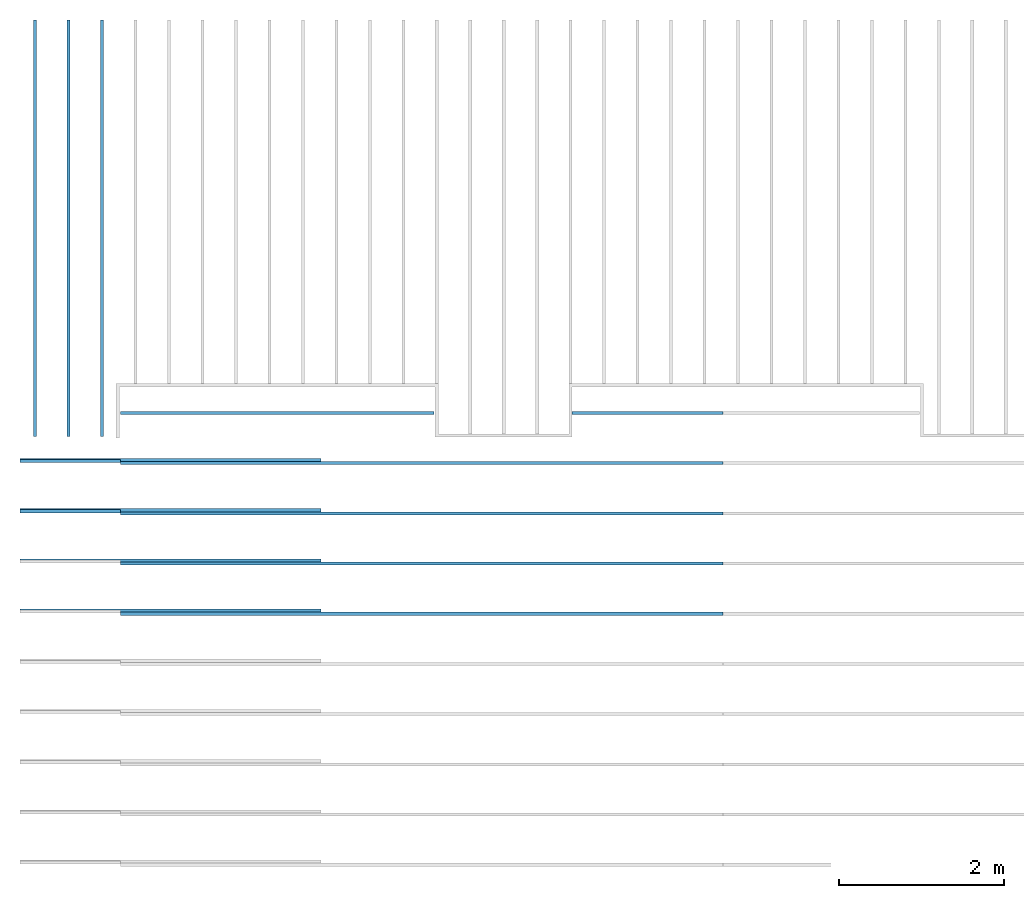
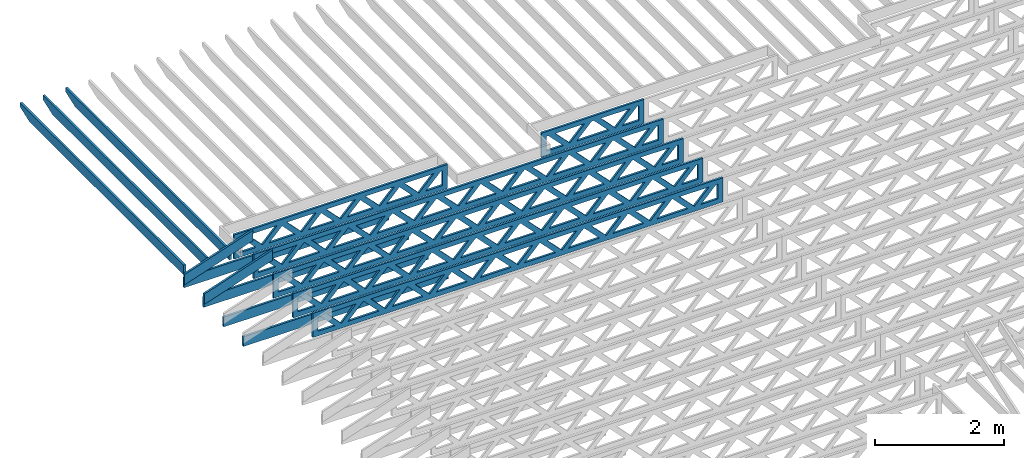
# One storey, part 4 of 18: 15 beams, 4 elements without a shape of their own.
"""IFC4 building model written with IfcOpenShell, lengths in feet."""

from ifc_helpers import new_model, entity, si_unit, converted_unit, derived_unit, direction, frame, frame_2d, origin, origin_2d_with_axis, place, context, subcontext, project, spatial, rectangle, extrude, clip, halfspace, source, transform, mapped, material, material_profile, profile_set, profile_usage, type_object, type_shapes, element, aggregate, save


model = new_model("IFC4")

# Units and contexts
model_context_1 = context("Model", 3, precision=0.0001, world=origin(), true_north=direction((6.12303176911189e-17, 1.0)))
model_context_2 = context("Model", 3, precision=0.0001, world=origin(), true_north=direction((6.12303176911189e-17, 1.0)))
body_context = subcontext(model_context_2, "Body", "Model", "MODEL_VIEW")
ifc_project = project(units=[converted_unit("LENGTHUNIT", "FOOT", entity("IfcRatioMeasure", 0.3048), si_unit("LENGTHUNIT", "METRE"), dimensions=[1, 0, 0, 0, 0, 0, 0]), converted_unit("AREAUNIT", "SQUARE FOOT", entity("IfcRatioMeasure", 0.09290304), si_unit("AREAUNIT", "SQUARE_METRE"), dimensions=[2, 0, 0, 0, 0, 0, 0]), converted_unit("VOLUMEUNIT", "CUBIC FOOT", entity("IfcRatioMeasure", 0.028316846592), si_unit("VOLUMEUNIT", "CUBIC_METRE"), dimensions=[3, 0, 0, 0, 0, 0, 0]), converted_unit("PLANEANGLEUNIT", "DEGREE", entity("IfcRatioMeasure", 0.0174532925199433), si_unit("PLANEANGLEUNIT", "RADIAN"), dimensions=[0, 0, 0, 0, 0, 0, 0]), si_unit("MASSUNIT", "GRAM", prefix="KILO"), derived_unit("MASSDENSITYUNIT", [(si_unit("MASSUNIT", "GRAM", prefix="KILO"), 1), (si_unit("LENGTHUNIT", "METRE"), -3)]), derived_unit("MOMENTOFINERTIAUNIT", [(si_unit("LENGTHUNIT", "METRE"), 4)]), si_unit("TIMEUNIT", "SECOND"), si_unit("FREQUENCYUNIT", "HERTZ"), si_unit("THERMODYNAMICTEMPERATUREUNIT", "DEGREE_CELSIUS"), derived_unit("THERMALTRANSMITTANCEUNIT", [(si_unit("MASSUNIT", "GRAM", prefix="KILO"), 1), (si_unit("THERMODYNAMICTEMPERATUREUNIT", "KELVIN"), -1), (si_unit("TIMEUNIT", "SECOND"), -3)]), derived_unit("VOLUMETRICFLOWRATEUNIT", [(si_unit("LENGTHUNIT", "METRE"), 3), (si_unit("TIMEUNIT", "SECOND"), -1)]), si_unit("ELECTRICCURRENTUNIT", "AMPERE"), si_unit("ELECTRICVOLTAGEUNIT", "VOLT"), si_unit("POWERUNIT", "WATT"), si_unit("FORCEUNIT", "NEWTON"), si_unit("ILLUMINANCEUNIT", "LUX"), si_unit("LUMINOUSFLUXUNIT", "LUMEN"), si_unit("LUMINOUSINTENSITYUNIT", "CANDELA"), derived_unit("USERDEFINED", [(si_unit("MASSUNIT", "GRAM", prefix="KILO"), -1), (si_unit("LENGTHUNIT", "METRE"), -2), (si_unit("TIMEUNIT", "SECOND"), 3), (si_unit("LUMINOUSFLUXUNIT", "LUMEN"), 1)]), derived_unit("LINEARVELOCITYUNIT", [(si_unit("LENGTHUNIT", "METRE"), 1), (si_unit("TIMEUNIT", "SECOND"), -1)]), si_unit("PRESSUREUNIT", "PASCAL"), derived_unit("USERDEFINED", [(si_unit("LENGTHUNIT", "METRE"), -2), (si_unit("MASSUNIT", "GRAM", prefix="KILO"), 1), (si_unit("TIMEUNIT", "SECOND"), -2)]), derived_unit("LINEARFORCEUNIT", [(si_unit("MASSUNIT", "GRAM", prefix="KILO"), 1), (si_unit("LENGTHUNIT", "METRE"), 1), (si_unit("TIMEUNIT", "SECOND"), -2), (si_unit("LENGTHUNIT", "METRE"), -1)]), derived_unit("PLANARFORCEUNIT", [(si_unit("MASSUNIT", "GRAM", prefix="KILO"), 1), (si_unit("LENGTHUNIT", "METRE"), 1), (si_unit("TIMEUNIT", "SECOND"), -2), (si_unit("LENGTHUNIT", "METRE"), -2)])], contexts=[model_context_1])

# Site, building, storey
site_placement = place(None, origin())
site = spatial("IfcSite", under=ifc_project, at=site_placement, CompositionType="ELEMENT")
building_placement = place(site_placement, origin())
building = spatial("IfcBuilding", under=site, at=building_placement, CompositionType="ELEMENT")
storey_placement = place(building_placement, frame((0.0, 0.0, 30.4375000000082)))
storey = spatial("IfcBuildingStorey", under=building, at=storey_placement, Name="ROOF", CompositionType="ELEMENT", Elevation=30.4375000000082)

# Assembly, beams
assembly_1_placement = place(storey_placement, origin())
assembly_1 = element("IfcElementAssembly", 1, at=assembly_1_placement, inside=storey, Name="Structural Beam System:Structural Framing System", ObjectType="Structural Beam System:Structural Framing System", AssemblyPlace="NOTDEFINED", PredefinedType="BEAM_GRID")
ifc_material_1 = material(Name="2X ROOF JOISTS - EXT. STAIN-1 - SEE LIFE SAFETY", Category="Materials")
ifc_material_profile_1 = material_profile(ifc_material_1, rectangle(XDim=0.604166666666667, YDim=0.125000000000011, at=frame_2d((0.0, 0.0), x_axis=(0.0, 1.0))))
ifc_profile_set_1 = profile_set([ifc_material_profile_1])
ifc_profile_usage_1 = profile_usage(ifc_profile_set_1, cardinal=8)
beam_type_1 = type_object("IfcBeamType", PredefinedType="BEAM", material=ifc_profile_set_1)
shared_shape_1 = source(origin(), body_context, "Body", "Clipping", [
    clip(extrude(rectangle(XDim=0.604166666666667, YDim=0.125000000000011, at=frame_2d((0.0, 0.0), x_axis=(0.0, 1.0))), frame((-8.29610169621611, 0.0, 0.0), z_axis=(1.0, 0.0, 0.0), x_axis=(0.0, 1.0, 0.0)), (0.0, 0.0, 1.0), 16.5922033924322), halfspace(frame((-7.32303677682588, -0.0625000000000026, -0.30208333333334), z_axis=(-0.34202014332567, 0.0, -0.939692620785908), x_axis=(0.0, 1.0, 0.0)), False)),
])
type_shapes(beam_type_1, [shared_shape_1])
beam_1_placement = place(assembly_1_placement, frame((-269.133993818795, 965.218429332857, 1.07291666665835), z_axis=(0.0, 0.0, 1.0), x_axis=(0.0, -1.0, 0.0)))
beam_1 = element("IfcBeam", 2, at=beam_1_placement, type_object=beam_type_1, material=ifc_profile_usage_1, PredefinedType="BEAM", context=body_context, shape_type="MappedRepresentation", body=[
    mapped(shared_shape_1, transform((0.0, 0.0, 0.0), scale=1.0)),
])
ifc_profile_usage_2 = profile_usage(ifc_profile_set_1, cardinal=8)
beam_2_placement = place(assembly_1_placement, frame((-267.800660485462, 965.218429332857, 1.07291666665835), z_axis=(0.0, 0.0, 1.0), x_axis=(0.0, -1.0, 0.0)))
beam_2 = element("IfcBeam", 3, at=beam_2_placement, type_object=beam_type_1, material=ifc_profile_usage_2, PredefinedType="BEAM", context=body_context, shape_type="MappedRepresentation", body=[
    mapped(shared_shape_1, transform((0.0, 0.0, 0.0), scale=1.0)),
])
ifc_profile_usage_3 = profile_usage(ifc_profile_set_1, cardinal=8)
beam_3_placement = place(assembly_1_placement, frame((-266.467327152129, 965.218429332857, 1.07291666665835), z_axis=(0.0, 0.0, 1.0), x_axis=(0.0, -1.0, 0.0)))
beam_3 = element("IfcBeam", 4, at=beam_3_placement, type_object=beam_type_1, material=ifc_profile_usage_3, PredefinedType="BEAM", context=body_context, shape_type="MappedRepresentation", body=[
    mapped(shared_shape_1, transform((0.0, 0.0, 0.0), scale=1.0)),
])
aggregate(assembly_1, [beam_1, beam_2, beam_3])

assembly_2_placement = place(storey_placement, origin())
assembly_2 = element("IfcElementAssembly", 5, at=assembly_2_placement, inside=storey, Name="Structural Beam System:Structural Framing System", ObjectType="Structural Beam System:Structural Framing System", AssemblyPlace="NOTDEFINED", PredefinedType="BEAM_GRID")
ifc_material_2 = material(Name="TOP CHORD OF FIELD FRAMED OVERHANG", Category="Materials")
ifc_material_profile_2 = material_profile(ifc_material_2, rectangle(XDim=0.604166666666667, YDim=0.125, at=origin_2d_with_axis()), Name="2X8 TOP CHORD")
ifc_profile_set_2 = profile_set([ifc_material_profile_2], Name="2X8 TOP CHORD")
ifc_profile_usage_4 = profile_usage(ifc_profile_set_2, cardinal=8)
beam_type_2 = type_object("IfcBeamType", Name="Dimension Lumber - Ends:2X8 TOP CHORD", PredefinedType="BEAM", material=ifc_profile_set_2)
shared_shape_2 = source(origin(), body_context, "Body", "Clipping", [
    clip(clip(extrude(rectangle(XDim=0.604166666666671, YDim=0.125, at=frame_2d((-1.83186799063151e-15, 0.0), x_axis=(1.0, 0.0))), frame((-2.10819527564865, 0.0, 0.0), z_axis=(1.0, 0.0, 0.0), x_axis=(0.0, 0.0, -1.0)), (0.0, 0.0, 1.0), 4.41772145980974), halfspace(frame((2.10819527564862, -0.0625000000000025, -0.302083333333339), z_axis=(0.948710608132914, 0.0, -0.316145823973807), x_axis=(0.0, 1.0, 0.0)), False)), halfspace(frame((-1.90686436713617, -0.0625000000000025, 0.302083333333328), z_axis=(-0.948710608132914, 0.0, 0.316145823973807), x_axis=(0.0, 1.0, 0.0)), False)),
])
type_shapes(beam_type_2, [shared_shape_2])
beam_4_placement = place(assembly_2_placement, frame((-267.833654839365, 953.945265019167, 1.93690371042362), z_axis=(-0.316227766016838, 0.0, 0.948683298050514), x_axis=(0.948683298050514, 0.0, 0.316227766016837)))
beam_4 = element("IfcBeam", 6, at=beam_4_placement, type_object=beam_type_2, material=ifc_profile_usage_4, Name="Dimension Lumber - Ends:2X8 TOP CHORD", ObjectType="Dimension Lumber - Ends:2X8 TOP CHORD", PredefinedType="BEAM", context=body_context, shape_type="MappedRepresentation", body=[
    mapped(shared_shape_2, transform((0.0, 0.0, 0.0), scale=1.0)),
])
ifc_profile_usage_5 = profile_usage(ifc_profile_set_2, cardinal=8)
beam_5_placement = place(assembly_2_placement, frame((-267.833654839365, 955.945265019167, 1.93690371042362), z_axis=(-0.316227766016838, 0.0, 0.948683298050514), x_axis=(0.948683298050514, 0.0, 0.316227766016837)))
beam_5 = element("IfcBeam", 7, at=beam_5_placement, type_object=beam_type_2, material=ifc_profile_usage_5, Name="Dimension Lumber - Ends:2X8 TOP CHORD", ObjectType="Dimension Lumber - Ends:2X8 TOP CHORD", PredefinedType="BEAM", context=body_context, shape_type="MappedRepresentation", body=[
    mapped(shared_shape_2, transform((0.0, 0.0, 0.0), scale=1.0)),
])
aggregate(assembly_2, [beam_4, beam_5])

assembly_3_placement = place(storey_placement, origin())
assembly_3 = element("IfcElementAssembly", 8, at=assembly_3_placement, inside=storey, Name="Structural Beam System:Structural Framing System", ObjectType="Structural Beam System:Structural Framing System", AssemblyPlace="NOTDEFINED", PredefinedType="BEAM_GRID")
ifc_material_3 = material(Name="2X8 TO ROOF", Category="Materials")
ifc_material_profile_3 = material_profile(ifc_material_3, rectangle(XDim=0.604166666666667, YDim=0.125000000000011, at=origin_2d_with_axis()), Name="2X8")
ifc_profile_set_3 = profile_set([ifc_material_profile_3], Name="2X8")
ifc_profile_usage_6 = profile_usage(ifc_profile_set_3, cardinal=8)
beam_type_3 = type_object("IfcBeamType", Name="061100 - Wood Framing:2X8", PredefinedType="BEAM", material=ifc_profile_set_3)
shared_shape_3 = source(origin(), body_context, "Body", "SweptSolid", [
    extrude(rectangle(XDim=0.604166666666667, YDim=0.125000000000011, at=origin_2d_with_axis()), frame((-6.0, 0.0, 0.0), z_axis=(1.0, 0.0, 0.0), x_axis=(0.0, 0.0, -1.0)), (0.0, 0.0, 1.0), 12.000000000033),
])
type_shapes(beam_type_3, [shared_shape_3])
beam_6_placement = place(assembly_3_placement, frame((-263.738072841597, 951.986939927996, 1.07291666665841), z_axis=(0.0, 0.0, 1.0), x_axis=(-1.0, 0.0, 0.0)))
beam_6 = element("IfcBeam", 9, at=beam_6_placement, type_object=beam_type_3, material=ifc_profile_usage_6, Name="061100 - Wood Framing:2X8", ObjectType="061100 - Wood Framing:2X8", PredefinedType="BEAM", context=body_context, shape_type="MappedRepresentation", body=[
    mapped(shared_shape_3, transform((0.0, 0.0, 0.0), scale=1.0)),
])
ifc_profile_usage_7 = profile_usage(ifc_profile_set_3, cardinal=8)
beam_7_placement = place(assembly_3_placement, frame((-263.738087916709, 949.986939927882, 1.07291666665841), z_axis=(0.0, 0.0, 1.0), x_axis=(-1.0, 0.0, 0.0)))
beam_7 = element("IfcBeam", 10, at=beam_7_placement, type_object=beam_type_3, material=ifc_profile_usage_7, Name="061100 - Wood Framing:2X8", ObjectType="061100 - Wood Framing:2X8", PredefinedType="BEAM", context=body_context, shape_type="MappedRepresentation", body=[
    mapped(shared_shape_3, transform((0.0, 0.0, 0.0), scale=1.0)),
])
ifc_profile_usage_8 = profile_usage(ifc_profile_set_3, cardinal=8)
beam_8_placement = place(assembly_3_placement, frame((-263.738042691372, 955.986939928224, 1.0729166666584), z_axis=(0.0, 0.0, 1.0), x_axis=(-1.0, 0.0, 0.0)))
beam_8 = element("IfcBeam", 11, at=beam_8_placement, type_object=beam_type_3, material=ifc_profile_usage_8, Name="061100 - Wood Framing:2X8", ObjectType="061100 - Wood Framing:2X8", PredefinedType="BEAM", context=body_context, shape_type="MappedRepresentation", body=[
    mapped(shared_shape_3, transform((0.0, 0.0, 0.0), scale=1.0)),
])
ifc_profile_usage_9 = profile_usage(ifc_profile_set_3, cardinal=8)
beam_9_placement = place(assembly_3_placement, frame((-263.738057766485, 953.98693992811, 1.0729166666584), z_axis=(0.0, 0.0, 1.0), x_axis=(-1.0, 0.0, 0.0)))
beam_9 = element("IfcBeam", 12, at=beam_9_placement, type_object=beam_type_3, material=ifc_profile_usage_9, Name="061100 - Wood Framing:2X8", ObjectType="061100 - Wood Framing:2X8", PredefinedType="BEAM", context=body_context, shape_type="MappedRepresentation", body=[
    mapped(shared_shape_3, transform((0.0, 0.0, 0.0), scale=1.0)),
])
aggregate(assembly_3, [beam_6, beam_7, beam_8, beam_9])

assembly_4_placement = place(storey_placement, origin())
assembly_4 = element("IfcElementAssembly", 13, at=assembly_4_placement, inside=storey, Name="Structural Beam System:Structural Framing System", ObjectType="Structural Beam System:Structural Framing System", AssemblyPlace="NOTDEFINED", PredefinedType="BEAM_GRID")
ifc_material_4 = material(Name="WOOD TRUSS", Category="Materials")
ifc_material_profile_4 = material_profile(ifc_material_4, rectangle(XDim=1.73473973950632, YDim=0.125, at=origin_2d_with_axis()))
ifc_material_profile_5 = material_profile(ifc_material_4, rectangle(XDim=1.73473973950633, YDim=0.125, at=frame_2d((-1.11022302462516e-16, 0.0), x_axis=(1.0, 0.0))))
ifc_material_profile_6 = material_profile(ifc_material_4, rectangle(XDim=1.73473973950632, YDim=0.125, at=origin_2d_with_axis()))
ifc_material_profile_7 = material_profile(ifc_material_4, rectangle(XDim=1.73473973950633, YDim=0.125, at=origin_2d_with_axis()))
ifc_material_profile_8 = material_profile(ifc_material_4, rectangle(XDim=1.73473973950632, YDim=0.125, at=frame_2d((-5.55111512312578e-17, 0.0), x_axis=(1.0, 0.0))))
ifc_material_profile_9 = material_profile(ifc_material_4, rectangle(XDim=1.73473973950633, YDim=0.125, at=frame_2d((-2.77555756156289e-16, 0.0), x_axis=(1.0, 0.0))))
ifc_material_profile_10 = material_profile(ifc_material_4, rectangle(XDim=1.73473973950632, YDim=0.125, at=frame_2d((-4.9960036108132e-16, 0.0), x_axis=(1.0, 0.0))))
ifc_material_profile_11 = material_profile(ifc_material_4, rectangle(XDim=1.73473973950633, YDim=0.125, at=frame_2d((4.44089209850063e-16, 0.0), x_axis=(1.0, 0.0))))
ifc_material_profile_12 = material_profile(ifc_material_4, rectangle(XDim=1.73473973950632, YDim=0.125, at=origin_2d_with_axis()))
ifc_material_profile_13 = material_profile(ifc_material_4, rectangle(XDim=1.73473973950633, YDim=0.125, at=frame_2d((-4.9960036108132e-16, 0.0), x_axis=(1.0, 0.0))))
ifc_material_profile_14 = material_profile(ifc_material_4, rectangle(XDim=0.291666666666664, YDim=0.125, at=frame_2d((-2.77555756156289e-17, 0.0), x_axis=(1.0, 0.0))))
ifc_material_profile_15 = material_profile(ifc_material_4, rectangle(XDim=0.291666666666628, YDim=0.124999999999995, at=frame_2d((-5.55111512312578e-17, 0.0), x_axis=(1.0, 0.0))))
ifc_material_profile_16 = material_profile(ifc_material_4, rectangle(XDim=0.916666666666666, YDim=0.125000000000003, at=frame_2d((-2.77555756156289e-17, 0.0), x_axis=(1.0, 0.0))))
ifc_material_profile_17 = material_profile(ifc_material_4, rectangle(XDim=0.916666666666651, YDim=0.125, at=frame_2d((-2.77555756156289e-17, 0.0), x_axis=(1.0, 0.0))))
ifc_profile_set_4 = profile_set([ifc_material_profile_4, ifc_material_profile_5, ifc_material_profile_6, ifc_material_profile_7, ifc_material_profile_8, ifc_material_profile_9, ifc_material_profile_10, ifc_material_profile_11, ifc_material_profile_12, ifc_material_profile_13, ifc_material_profile_14, ifc_material_profile_15, ifc_material_profile_16, ifc_material_profile_17])
ifc_profile_usage_10 = profile_usage(ifc_profile_set_4, cardinal=8)
beam_type_4 = type_object("IfcBeamType", PredefinedType="BEAM", material=ifc_profile_set_4)
shared_shape_4 = source(origin(), body_context, "Body", "SweptSolid", [
    extrude(rectangle(XDim=1.73473973950632, YDim=0.125, at=frame_2d((8.88178419700125e-16, 0.0), x_axis=(1.0, 0.0))), frame((8.27006284966195, 0.0, 0.101118361020562), z_axis=(0.720569184836762, 0.0, -0.693383046997606), x_axis=(0.693383046997606, 0.0, 0.720569184836762)), (0.0, 0.0, 1.0), 0.291666666666667),
    extrude(rectangle(XDim=1.73473973950633, YDim=0.125, at=frame_2d((4.9960036108132e-16, 0.0), x_axis=(1.0, 0.0))), frame((7.01977697598868, 0.0, -0.101118361020407), z_axis=(0.720569184836758, 0.0, 0.69338304699761), x_axis=(0.69338304699761, 0.0, -0.720569184836758)), (0.0, 0.0, 1.0), 0.291666666666667),
    extrude(rectangle(XDim=1.73473973950632, YDim=0.125, at=origin_2d_with_axis()), frame((5.68672854334628, 0.0, 0.101118361020562), z_axis=(0.720569184836762, 0.0, -0.693383046997606), x_axis=(0.693383046997606, 0.0, 0.720569184836762)), (0.0, 0.0, 1.0), 0.291666666666667),
    extrude(rectangle(XDim=1.73473973950633, YDim=0.125, at=frame_2d((-4.9960036108132e-16, 0.0), x_axis=(1.0, 0.0))), frame((4.43644266967301, 0.0, -0.101118361020407), z_axis=(0.720569184836758, 0.0, 0.69338304699761), x_axis=(0.69338304699761, 0.0, -0.720569184836758)), (0.0, 0.0, 1.0), 0.291666666666667),
    extrude(rectangle(XDim=1.73473973950632, YDim=0.125, at=frame_2d((3.33066907387547e-16, 0.0), x_axis=(1.0, 0.0))), frame((3.10339423703061, 0.0, 0.101118361020562), z_axis=(0.720569184836762, 0.0, -0.693383046997606), x_axis=(0.693383046997606, 0.0, 0.720569184836762)), (0.0, 0.0, 1.0), 0.291666666666667),
    extrude(rectangle(XDim=1.73473973950633, YDim=0.125, at=frame_2d((-1.11022302462516e-16, 0.0), x_axis=(1.0, 0.0))), frame((1.85310836335734, 0.0, -0.101118361020407), z_axis=(0.720569184836758, 0.0, 0.69338304699761), x_axis=(0.69338304699761, 0.0, -0.720569184836758)), (0.0, 0.0, 1.0), 0.291666666666666),
    extrude(rectangle(XDim=1.73473973950632, YDim=0.125, at=frame_2d((5.55111512312578e-17, 0.0), x_axis=(1.0, 0.0))), frame((0.520059930714937, 0.0, 0.101118361020562), z_axis=(0.720569184836762, 0.0, -0.693383046997606), x_axis=(0.693383046997606, 0.0, 0.720569184836762)), (0.0, 0.0, 1.0), 0.291666666666667),
    extrude(rectangle(XDim=1.73473973950633, YDim=0.125, at=origin_2d_with_axis()), frame((-0.730225942958334, 0.0, -0.101118361020407), z_axis=(0.720569184836758, 0.0, 0.69338304699761), x_axis=(0.69338304699761, 0.0, -0.720569184836758)), (0.0, 0.0, 1.0), 0.291666666666666),
    extrude(rectangle(XDim=1.73473973950632, YDim=0.125, at=frame_2d((-5.55111512312578e-17, 0.0), x_axis=(1.0, 0.0))), frame((-2.06327437560074, 0.0, 0.101118361020562), z_axis=(0.720569184836762, 0.0, -0.693383046997606), x_axis=(0.693383046997606, 0.0, 0.720569184836762)), (0.0, 0.0, 1.0), 0.291666666666667),
    extrude(rectangle(XDim=1.73473973950633, YDim=0.125, at=frame_2d((-2.77555756156289e-16, 0.0), x_axis=(1.0, 0.0))), frame((-3.31356024927401, 0.0, -0.101118361020407), z_axis=(0.720569184836758, 0.0, 0.69338304699761), x_axis=(0.69338304699761, 0.0, -0.720569184836758)), (0.0, 0.0, 1.0), 0.291666666666666),
    extrude(rectangle(XDim=1.73473973950632, YDim=0.125, at=origin_2d_with_axis()), frame((-4.64660868191641, 0.0, 0.101118361020562), z_axis=(0.720569184836762, 0.0, -0.693383046997606), x_axis=(0.693383046997606, 0.0, 0.720569184836762)), (0.0, 0.0, 1.0), 0.291666666666667),
    extrude(rectangle(XDim=1.73473973950633, YDim=0.125, at=frame_2d((-4.9960036108132e-16, 0.0), x_axis=(1.0, 0.0))), frame((-5.89689455558968, 0.0, -0.101118361020407), z_axis=(0.720569184836758, 0.0, 0.69338304699761), x_axis=(0.69338304699761, 0.0, -0.720569184836758)), (0.0, 0.0, 1.0), 0.291666666666667),
    extrude(rectangle(XDim=1.73473973950632, YDim=0.125, at=frame_2d((5.55111512312578e-16, 0.0), x_axis=(1.0, 0.0))), frame((-7.22994298823208, 0.0, 0.101118361020562), z_axis=(0.720569184836762, 0.0, -0.693383046997606), x_axis=(0.693383046997606, 0.0, 0.720569184836762)), (0.0, 0.0, 1.0), 0.291666666666667),
    extrude(rectangle(XDim=1.73473973950633, YDim=0.125, at=origin_2d_with_axis()), frame((-8.48022886190535, 0.0, -0.101118361020407), z_axis=(0.720569184836758, 0.0, 0.69338304699761), x_axis=(0.69338304699761, 0.0, -0.720569184836758)), (0.0, 0.0, 1.0), 0.291666666666666),
    extrude(rectangle(XDim=1.73473973950632, YDim=0.125, at=frame_2d((-8.88178419700125e-16, 0.0), x_axis=(1.0, 0.0))), frame((10.8533971559776, 0.0, 0.101118361020503), z_axis=(0.720569184836762, 0.0, -0.693383046997606), x_axis=(0.693383046997606, 0.0, 0.720569184836762)), (0.0, 0.0, 1.0), 0.291666666666664),
    extrude(rectangle(XDim=1.73473973950633, YDim=0.125, at=origin_2d_with_axis()), frame((9.60311128230435, 0.0, -0.101118361020466), z_axis=(0.720569184836758, 0.0, 0.69338304699761), x_axis=(0.69338304699761, 0.0, -0.720569184836758)), (0.0, 0.0, 1.0), 0.291666666666666),
    extrude(rectangle(XDim=1.73473973950632, YDim=0.125, at=frame_2d((8.88178419700125e-16, 0.0), x_axis=(1.0, 0.0))), frame((-9.81327729454775, 0.0, 0.101118361020564), z_axis=(0.720569184836762, 0.0, -0.693383046997606), x_axis=(0.693383046997606, 0.0, 0.720569184836762)), (0.0, 0.0, 1.0), 0.291666666666667),
    extrude(rectangle(XDim=1.73473973950633, YDim=0.125, at=origin_2d_with_axis()), frame((-11.063563168221, 0.0, -0.101118361020405), z_axis=(0.720569184836758, 0.0, 0.69338304699761), x_axis=(0.69338304699761, 0.0, -0.720569184836758)), (0.0, 0.0, 1.0), 0.291666666666666),
    extrude(rectangle(XDim=0.291666666666664, YDim=0.125, at=frame_2d((-2.77555756156289e-17, 0.0), x_axis=(1.0, 0.0))), frame((-12.0000038919293, 0.0, 0.604166666666611), z_axis=(1.0, 0.0, 0.0), x_axis=(0.0, 0.0, -1.0)), (0.0, 0.0, 1.0), 24.0000077838585),
    extrude(rectangle(XDim=0.291666666666628, YDim=0.124999999999995, at=frame_2d((-5.55111512312578e-17, 0.0), x_axis=(1.0, 0.0))), frame((-12.0000038919291, 0.0, -0.604166666666693), z_axis=(1.0, 0.0, 0.0), x_axis=(0.0, 0.0, -1.0)), (0.0, 0.0, 1.0), 24.0000077838583),
    extrude(rectangle(XDim=0.916666666666666, YDim=0.125000000000003, at=frame_2d((-2.77555756156289e-17, 0.0), x_axis=(1.0, 0.0))), frame((11.7083372252626, 0.0, 0.0), z_axis=(1.0, 0.0, 0.0), x_axis=(0.0, 0.0, -1.0)), (0.0, 0.0, 1.0), 0.291666666666687),
    extrude(rectangle(XDim=0.916666666666651, YDim=0.125, at=frame_2d((-2.77555756156289e-17, 0.0), x_axis=(1.0, 0.0))), frame((-12.0000038919293, 0.0, 0.0), z_axis=(1.0, 0.0, 0.0), x_axis=(0.0, 0.0, -1.0)), (0.0, 0.0, 1.0), 0.291666666666687),
])
type_shapes(beam_type_4, [shared_shape_4])
beam_10_placement = place(assembly_4_placement, frame((-253.738164377457, 949.861934882651, 0.749999999991633)))
beam_10 = element("IfcBeam", 14, at=beam_10_placement, type_object=beam_type_4, material=ifc_profile_usage_10, PredefinedType="BEAM", context=body_context, shape_type="MappedRepresentation", body=[
    mapped(shared_shape_4, transform((0.0, 0.0, 0.0), scale=1.0)),
])
ifc_profile_usage_11 = profile_usage(ifc_profile_set_4, cardinal=8)
beam_11_placement = place(assembly_4_placement, frame((-253.738164377457, 955.861934882651, 0.749999999991619)))
beam_11 = element("IfcBeam", 15, at=beam_11_placement, type_object=beam_type_4, material=ifc_profile_usage_11, PredefinedType="BEAM", context=body_context, shape_type="MappedRepresentation", body=[
    mapped(shared_shape_4, transform((0.0, 0.0, 0.0), scale=1.0)),
])
ifc_profile_usage_12 = profile_usage(ifc_profile_set_4, cardinal=8)
beam_12_placement = place(assembly_4_placement, frame((-253.738164377457, 951.861934882651, 0.74999999999163)))
beam_12 = element("IfcBeam", 16, at=beam_12_placement, type_object=beam_type_4, material=ifc_profile_usage_12, PredefinedType="BEAM", context=body_context, shape_type="MappedRepresentation", body=[
    mapped(shared_shape_4, transform((0.0, 0.0, 0.0), scale=1.0)),
])
ifc_profile_usage_13 = profile_usage(ifc_profile_set_4, cardinal=8)
beam_13_placement = place(assembly_4_placement, frame((-253.738164377457, 953.861934882651, 0.749999999991623)))
beam_13 = element("IfcBeam", 17, at=beam_13_placement, type_object=beam_type_4, material=ifc_profile_usage_13, PredefinedType="BEAM", context=body_context, shape_type="MappedRepresentation", body=[
    mapped(shared_shape_4, transform((0.0, 0.0, 0.0), scale=1.0)),
])
ifc_profile_usage_14 = profile_usage(ifc_profile_set_4, cardinal=8)
beam_type_5 = type_object("IfcBeamType", PredefinedType="BEAM", material=ifc_profile_set_4)
shared_shape_5 = source(origin(), body_context, "Body", "SweptSolid", [
    extrude(rectangle(XDim=1.73473973950632, YDim=0.125, at=origin_2d_with_axis()), frame((2.81172855039779, 0.0, 0.101118361020562), z_axis=(0.720569184836762, 0.0, -0.693383046997606), x_axis=(0.693383046997606, 0.0, 0.720569184836762)), (0.0, 0.0, 1.0), 0.291666666666667),
    extrude(rectangle(XDim=1.73473973950633, YDim=0.125, at=frame_2d((-1.11022302462516e-16, 0.0), x_axis=(1.0, 0.0))), frame((1.56144267672452, 0.0, -0.101118361020407), z_axis=(0.720569184836758, 0.0, 0.69338304699761), x_axis=(0.69338304699761, 0.0, -0.720569184836758)), (0.0, 0.0, 1.0), 0.291666666666666),
    extrude(rectangle(XDim=1.73473973950632, YDim=0.125, at=origin_2d_with_axis()), frame((0.520059930714936, 0.0, 0.101118361020562), z_axis=(0.720569184836762, 0.0, -0.693383046997606), x_axis=(0.693383046997606, 0.0, 0.720569184836762)), (0.0, 0.0, 1.0), 0.291666666666667),
    extrude(rectangle(XDim=1.73473973950633, YDim=0.125, at=origin_2d_with_axis()), frame((-0.730225942958334, 0.0, -0.101118361020407), z_axis=(0.720569184836758, 0.0, 0.69338304699761), x_axis=(0.69338304699761, 0.0, -0.720569184836758)), (0.0, 0.0, 1.0), 0.291666666666666),
    extrude(rectangle(XDim=1.73473973950632, YDim=0.125, at=frame_2d((-5.55111512312578e-17, 0.0), x_axis=(1.0, 0.0))), frame((-1.77160868896792, 0.0, 0.101118361020562), z_axis=(0.720569184836762, 0.0, -0.693383046997606), x_axis=(0.693383046997606, 0.0, 0.720569184836762)), (0.0, 0.0, 1.0), 0.291666666666667),
    extrude(rectangle(XDim=1.73473973950633, YDim=0.125, at=frame_2d((-2.77555756156289e-16, 0.0), x_axis=(1.0, 0.0))), frame((-3.02189456264119, 0.0, -0.101118361020407), z_axis=(0.720569184836758, 0.0, 0.69338304699761), x_axis=(0.69338304699761, 0.0, -0.720569184836758)), (0.0, 0.0, 1.0), 0.291666666666666),
    extrude(rectangle(XDim=1.73473973950632, YDim=0.125, at=frame_2d((-4.9960036108132e-16, 0.0), x_axis=(1.0, 0.0))), frame((5.10339717008065, 0.0, 0.101118361020511), z_axis=(0.720569184836761, 0.0, -0.693383046997607), x_axis=(0.693383046997607, 0.0, 0.720569184836761)), (0.0, 0.0, 1.0), 0.291666666666668),
    extrude(rectangle(XDim=1.73473973950633, YDim=0.125, at=frame_2d((4.44089209850063e-16, 0.0), x_axis=(1.0, 0.0))), frame((3.85311129640737, 0.0, -0.101118361020458), z_axis=(0.720569184836758, 0.0, 0.69338304699761), x_axis=(0.69338304699761, 0.0, -0.720569184836758)), (0.0, 0.0, 1.0), 0.291666666666666),
    extrude(rectangle(XDim=1.73473973950632, YDim=0.125, at=origin_2d_with_axis()), frame((-4.06327730865077, 0.0, 0.101118361020557), z_axis=(0.720569184836762, 0.0, -0.693383046997606), x_axis=(0.693383046997606, 0.0, 0.720569184836762)), (0.0, 0.0, 1.0), 0.291666666666668),
    extrude(rectangle(XDim=1.73473973950633, YDim=0.125, at=frame_2d((-4.9960036108132e-16, 0.0), x_axis=(1.0, 0.0))), frame((-5.31356318232404, 0.0, -0.101118361020412), z_axis=(0.720569184836758, 0.0, 0.69338304699761), x_axis=(0.69338304699761, 0.0, -0.720569184836758)), (0.0, 0.0, 1.0), 0.291666666666667),
    extrude(rectangle(XDim=0.291666666666664, YDim=0.125, at=frame_2d((-2.77555756156289e-17, 0.0), x_axis=(1.0, 0.0))), frame((-6.25000390603229, 0.0, 0.604166666666611), z_axis=(1.0, 0.0, 0.0), x_axis=(0.0, 0.0, -1.0)), (0.0, 0.0, 1.0), 12.5000078120646),
    extrude(rectangle(XDim=0.291666666666628, YDim=0.124999999999995, at=frame_2d((-5.55111512312578e-17, 0.0), x_axis=(1.0, 0.0))), frame((-6.25000390603208, 0.0, -0.604166666666693), z_axis=(1.0, 0.0, 0.0), x_axis=(0.0, 0.0, -1.0)), (0.0, 0.0, 1.0), 12.5000078120644),
    extrude(rectangle(XDim=0.916666666666666, YDim=0.125000000000003, at=frame_2d((-2.77555756156289e-17, 0.0), x_axis=(1.0, 0.0))), frame((5.9583372393656, 0.0, 0.0), z_axis=(1.0, 0.0, 0.0), x_axis=(0.0, 0.0, -1.0)), (0.0, 0.0, 1.0), 0.291666666666687),
    extrude(rectangle(XDim=0.916666666666651, YDim=0.125, at=frame_2d((-2.77555756156289e-17, 0.0), x_axis=(1.0, 0.0))), frame((-6.25000390603229, 0.0, 0.0), z_axis=(1.0, 0.0, 0.0), x_axis=(0.0, 0.0, -1.0)), (0.0, 0.0, 1.0), 0.291666666666687),
])
type_shapes(beam_type_5, [shared_shape_5])
beam_14_placement = place(assembly_4_placement, frame((-259.488164363354, 957.861934882651, 0.749999999991619)))
beam_14 = element("IfcBeam", 18, at=beam_14_placement, type_object=beam_type_5, material=ifc_profile_usage_14, PredefinedType="BEAM", context=body_context, shape_type="MappedRepresentation", body=[
    mapped(shared_shape_5, transform((0.0, 0.0, 0.0), scale=1.0)),
])
ifc_profile_usage_15 = profile_usage(ifc_profile_set_4, cardinal=8)
beam_type_6 = type_object("IfcBeamType", PredefinedType="BEAM", material=ifc_profile_set_4)
shared_shape_6 = source(origin(), body_context, "Body", "SweptSolid", [
    extrude(rectangle(XDim=1.73473973950632, YDim=0.125, at=frame_2d((5.55111512312578e-17, 0.0), x_axis=(1.0, 0.0))), frame((1.853392761574, 0.0, 0.101118361020515), z_axis=(0.720569184836762, 0.0, -0.693383046997606), x_axis=(0.693383046997606, 0.0, 0.720569184836762)), (0.0, 0.0, 1.0), 0.291666666666667),
    extrude(rectangle(XDim=1.73473973950633, YDim=0.125, at=frame_2d((-1.11022302462516e-16, 0.0), x_axis=(1.0, 0.0))), frame((0.603106887900734, 0.0, -0.101118361020454), z_axis=(0.720569184836758, 0.0, 0.69338304699761), x_axis=(0.69338304699761, 0.0, -0.720569184836758)), (0.0, 0.0, 1.0), 0.291666666666667),
    extrude(rectangle(XDim=1.73473973950632, YDim=0.125, at=frame_2d((-5.55111512312578e-17, 0.0), x_axis=(1.0, 0.0))), frame((-0.813272900144133, 0.0, 0.101118361020554), z_axis=(0.720569184836762, 0.0, -0.693383046997606), x_axis=(0.693383046997606, 0.0, 0.720569184836762)), (0.0, 0.0, 1.0), 0.291666666666667),
    extrude(rectangle(XDim=1.73473973950633, YDim=0.125, at=frame_2d((-1.66533453693773e-16, 0.0), x_axis=(1.0, 0.0))), frame((-2.0635587738174, 0.0, -0.101118361020415), z_axis=(0.720569184836758, 0.0, 0.69338304699761), x_axis=(0.69338304699761, 0.0, -0.720569184836758)), (0.0, 0.0, 1.0), 0.291666666666666),
    extrude(rectangle(XDim=0.291666666666664, YDim=0.125, at=frame_2d((-2.77555756156289e-17, 0.0), x_axis=(1.0, 0.0))), frame((-2.99999949752565, 0.0, 0.604166666666611), z_axis=(1.0, 0.0, 0.0), x_axis=(0.0, 0.0, -1.0)), (0.0, 0.0, 1.0), 5.9999989950513),
    extrude(rectangle(XDim=0.291666666666628, YDim=0.124999999999995, at=frame_2d((-5.55111512312578e-17, 0.0), x_axis=(1.0, 0.0))), frame((-2.99999949752544, 0.0, -0.604166666666693), z_axis=(1.0, 0.0, 0.0), x_axis=(0.0, 0.0, -1.0)), (0.0, 0.0, 1.0), 5.99999899505109),
    extrude(rectangle(XDim=0.916666666666666, YDim=0.125000000000003, at=frame_2d((-2.77555756156289e-17, 0.0), x_axis=(1.0, 0.0))), frame((2.70833283085896, 0.0, 0.0), z_axis=(1.0, 0.0, 0.0), x_axis=(0.0, 0.0, -1.0)), (0.0, 0.0, 1.0), 0.291666666666687),
    extrude(rectangle(XDim=0.916666666666651, YDim=0.125, at=frame_2d((-2.77555756156289e-17, 0.0), x_axis=(1.0, 0.0))), frame((-2.99999949752565, 0.0, 0.0), z_axis=(1.0, 0.0, 0.0), x_axis=(0.0, 0.0, -1.0)), (0.0, 0.0, 1.0), 0.291666666666687),
])
type_shapes(beam_type_6, [shared_shape_6])
beam_15_placement = place(assembly_4_placement, frame((-244.738159983054, 957.861934882651, 0.749999999991616)))
beam_15 = element("IfcBeam", 19, at=beam_15_placement, type_object=beam_type_6, material=ifc_profile_usage_15, PredefinedType="BEAM", context=body_context, shape_type="MappedRepresentation", body=[
    mapped(shared_shape_6, transform((0.0, 0.0, 0.0), scale=1.0)),
])
aggregate(assembly_4, [beam_10, beam_11, beam_14, beam_15, beam_12, beam_13])

save(model, "model.ifc")
